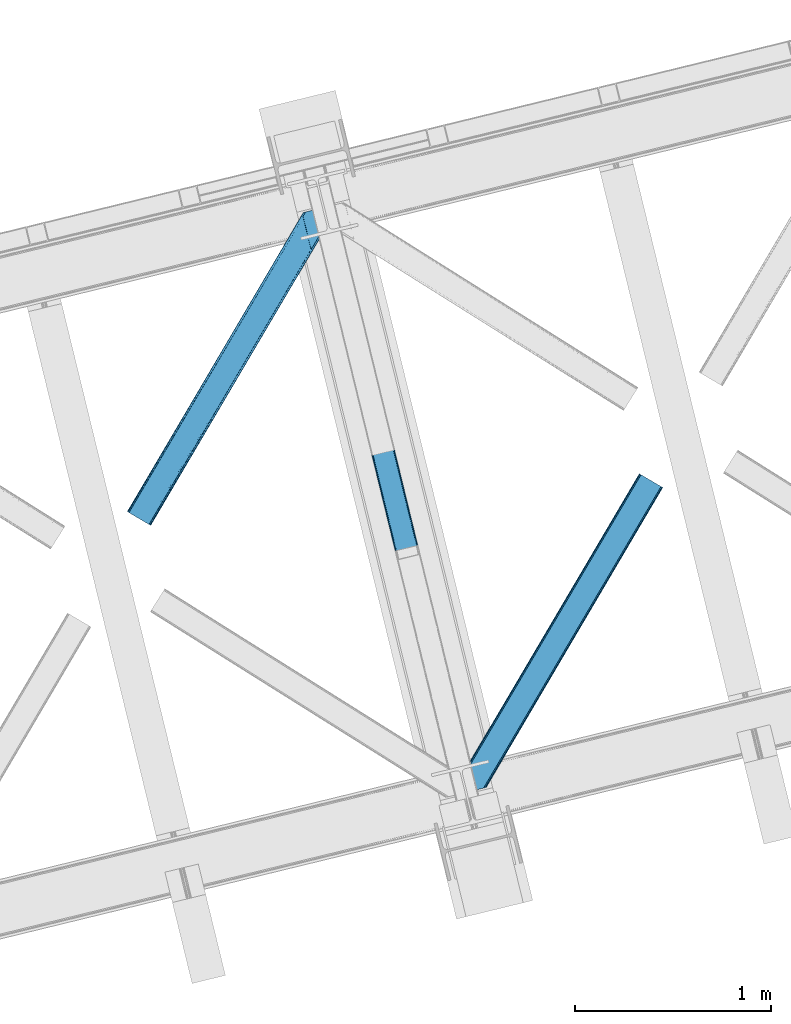
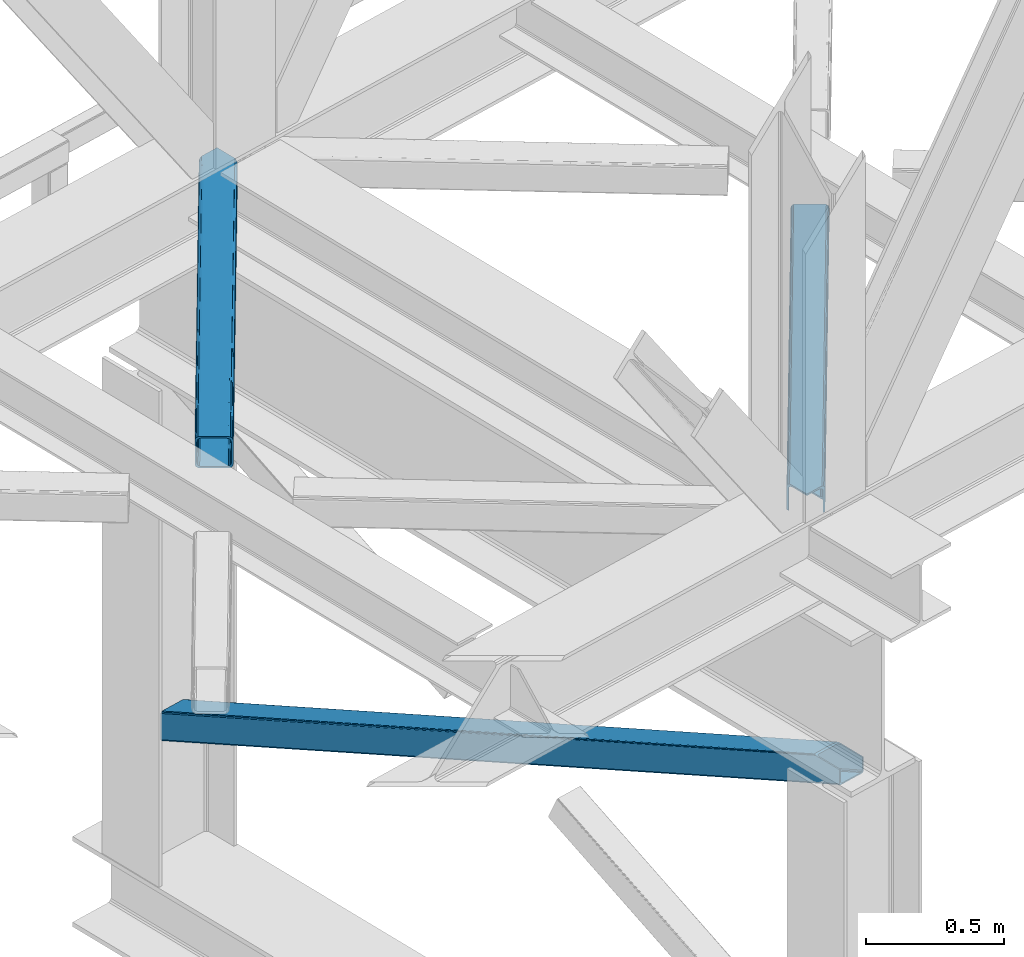
# One storey, part 29 of 93: 3 members.
"""IFC4 building model written with IfcOpenShell, lengths in millimetres."""

from ifc_helpers import new_model, entity, si_unit, converted_unit, derived_unit, direction, frame, origin, place, context, subcontext, project, spatial, triangles, type_object, element, save


model = new_model("IFC4")

# Units and contexts
model_context = context("Model", 3, precision=0.01, world=origin(), true_north=direction((6.12303176911189e-17, 1.0)))
plan_context = context("Plan", 3, precision=0.01, world=origin(), true_north=direction((6.12303176911189e-17, 1.0)))
body_context = subcontext(model_context, "Body", "Model", "MODEL_VIEW")
ifc_project = project(units=[si_unit("LENGTHUNIT", "METRE", prefix="MILLI"), si_unit("AREAUNIT", "SQUARE_METRE"), si_unit("VOLUMEUNIT", "CUBIC_METRE"), converted_unit("PLANEANGLEUNIT", "DEGREE", entity("IfcRatioMeasure", 0.0174532925199433), si_unit("PLANEANGLEUNIT", "RADIAN"), dimensions=[0, 0, 0, 0, 0, 0, 0]), si_unit("MASSUNIT", "GRAM", prefix="KILO"), derived_unit("MASSDENSITYUNIT", [(si_unit("MASSUNIT", "GRAM", prefix="KILO"), 1), (si_unit("LENGTHUNIT", "METRE"), -3)]), derived_unit("MOMENTOFINERTIAUNIT", [(si_unit("LENGTHUNIT", "METRE"), 4)]), si_unit("TIMEUNIT", "SECOND"), si_unit("FREQUENCYUNIT", "HERTZ"), si_unit("THERMODYNAMICTEMPERATUREUNIT", "DEGREE_CELSIUS"), derived_unit("THERMALTRANSMITTANCEUNIT", [(si_unit("MASSUNIT", "GRAM", prefix="KILO"), 1), (si_unit("THERMODYNAMICTEMPERATUREUNIT", "KELVIN"), -1), (si_unit("TIMEUNIT", "SECOND"), -3)]), derived_unit("VOLUMETRICFLOWRATEUNIT", [(si_unit("LENGTHUNIT", "METRE"), 3), (si_unit("TIMEUNIT", "SECOND"), -1)]), derived_unit("MASSFLOWRATEUNIT", [(si_unit("MASSUNIT", "GRAM", prefix="KILO"), 1), (si_unit("TIMEUNIT", "SECOND"), -1)]), derived_unit("ROTATIONALFREQUENCYUNIT", [(si_unit("TIMEUNIT", "SECOND"), -1)]), si_unit("ELECTRICCURRENTUNIT", "AMPERE"), si_unit("ELECTRICVOLTAGEUNIT", "VOLT"), si_unit("POWERUNIT", "WATT"), si_unit("FORCEUNIT", "NEWTON", prefix="KILO"), si_unit("ILLUMINANCEUNIT", "LUX"), si_unit("LUMINOUSFLUXUNIT", "LUMEN"), si_unit("LUMINOUSINTENSITYUNIT", "CANDELA"), derived_unit("USERDEFINED", [(si_unit("MASSUNIT", "GRAM", prefix="KILO"), -1), (si_unit("LENGTHUNIT", "METRE"), -2), (si_unit("TIMEUNIT", "SECOND"), 3), (si_unit("LUMINOUSFLUXUNIT", "LUMEN"), 1)]), derived_unit("LINEARVELOCITYUNIT", [(si_unit("LENGTHUNIT", "METRE"), 1), (si_unit("TIMEUNIT", "SECOND"), -1)]), si_unit("PRESSUREUNIT", "PASCAL"), derived_unit("USERDEFINED", [(si_unit("LENGTHUNIT", "METRE"), -2), (si_unit("MASSUNIT", "GRAM", prefix="KILO"), 1), (si_unit("TIMEUNIT", "SECOND"), -2)]), derived_unit("LINEARFORCEUNIT", [(si_unit("MASSUNIT", "GRAM", prefix="KILO"), 1), (si_unit("LENGTHUNIT", "METRE"), 1), (si_unit("TIMEUNIT", "SECOND"), -2), (si_unit("LENGTHUNIT", "METRE"), -1)]), derived_unit("PLANARFORCEUNIT", [(si_unit("MASSUNIT", "GRAM", prefix="KILO"), 1), (si_unit("LENGTHUNIT", "METRE"), 1), (si_unit("TIMEUNIT", "SECOND"), -2), (si_unit("LENGTHUNIT", "METRE"), -2)])], contexts=[model_context, plan_context])

# Site, building, storey
site_placement = place(None, origin())
site = spatial("IfcSite", under=ifc_project, at=site_placement, CompositionType="ELEMENT")
building_placement = place(site_placement, origin())
building = spatial("IfcBuilding", under=site, at=building_placement, CompositionType="ELEMENT")
storey_placement = place(building_placement, frame((0.0, 0.0, 15900.0)))
storey = spatial("IfcBuildingStorey", under=building, at=storey_placement, CompositionType="ELEMENT", Elevation=15900.0)

# Members
member_type_1 = type_object("IfcMemberType", PredefinedType="BRACE")
member_1_placement = place(storey_placement, frame((-55294.262109375, 4087.91210632324, 911.279672241211)))
element("IfcMember", 1, at=member_1_placement, inside=storey, type_object=member_type_1, ObjectType="Steel Vertical Brace", PredefinedType="BRACE", context=body_context, shape_type="Tessellation", body=[
    triangles([(109.783996582031, 3493.74488525391, 0.0), (954.899853515621, 26.7611572265623, 1610.78191223144), (6.79958496093604, 3468.64118499756, 0.0), (851.915441894525, 1.65774765014658, 1610.78191223144), (112.188500976561, 3494.33089599609, 1.12551269531104), (957.30435791015, 27.3474586486818, 1611.90626220703), (114.593005371091, 3494.91690673828, 2.24986267089844), (959.708862304688, 27.9334693908695, 1613.03061218261), (115.588293457025, 3495.15991516113, 4.96481323242188), (960.704150390622, 28.1761871337894, 1615.74672546387), (116.588232421869, 3495.40234222412, 7.68092651366896), (961.699438476557, 28.4189048767093, 1618.46167602539), (0.99528808593459, 3467.22615509033, 4.96481323242188), (846.111145019531, 0.242717742919922, 1615.74672546387), (0.0, 3466.98372802734, 7.68092651366896), (845.115856933589, 0.0, 1618.46167602539), (1.99057617186918, 3467.46916351318, 2.24986267089844), (847.106433105466, 0.485435485839844, 1613.03061218261), (4.39508056640625, 3468.05517425537, 1.12551269531104), (849.510937499996, 1.07144622802753, 1611.90626220703), (933.347680664061, 144.732444763184, 1680.7206665039), (116.588232421869, 3495.40234222412, 123.979641723632), (961.699438476557, 28.4189048767093, 1680.7206665039), (816.759448242185, 116.313539886474, 1680.7206665039), (0.0, 3466.98372802734, 123.979641723632), (845.115856933589, 0.0, 1680.7206665039), (112.188500976561, 3494.33089599609, 130.53505554199), (109.783996582031, 3493.74488525391, 131.659405517577), (922.5157836914, 159.605083465576, 1680.7206665039), (114.593005371091, 3494.91690673828, 129.409542846679), (925.427233886716, 158.980993652343, 1680.7206665039), (115.588293457025, 3495.15991516113, 126.694592285156), (928.506115722652, 155.935830688477, 1680.7206665039), (931.287341308591, 150.932357025146, 1680.7206665039), (6.79958496093604, 3468.64118499756, 131.659405517577), (819.531372070313, 134.501383209228, 1680.7206665039), (815.73625488281, 122.76547164917, 1680.7206665039), (0.99528808593459, 3467.22615509033, 126.694592285156), (815.903686523438, 128.487506103515, 1680.7206665039), (1.99057617186918, 3467.46916351318, 129.409542846679), (817.23848876953, 132.608766174317, 1680.7206665039), (4.39508056640625, 3468.05517425537, 130.53505554199), (923.44595947265, 145.989635467529, 1680.7206665039), (926.524841308594, 142.94418182373, 1680.7206665039), (920.539160156244, 146.61343460083, 1680.7206665039), (931.366406249996, 131.74108657837, 1680.7206665039), (956.843920898435, 27.2349655151365, 1680.7206665039), (929.306066894525, 137.9407081604, 1680.7206665039), (823.638098144525, 117.864317321777, 1680.7206665039), (824.972900390625, 121.985577392578, 1680.7206665039), (827.27043457031, 123.878194427491, 1680.7206665039), (824.498510742182, 105.690060424805, 1680.7206665039), (823.475317382807, 112.142282867431, 1680.7206665039), (849.971374511719, 1.18393936157236, 1680.7206665039), (111.728063964838, 3494.21869354248, 118.492767333984), (110.732775878903, 3493.97568511963, 121.208880615231), (109.737487792969, 3493.73267669678, 123.923831176755), (107.332983398432, 3493.14666595459, 125.048181152342), (104.928479003902, 3492.5606552124, 126.173693847653), (11.6597534179673, 3469.82541503906, 126.173693847653), (9.2552490234375, 3469.23940429688, 125.048181152342), (6.85074462890043, 3468.65339355469, 123.923831176755), (5.85545654296584, 3468.41038513184, 121.208880615231), (4.85551757812209, 3468.16737670898, 118.492767333984), (111.728063964838, 3494.21869354248, 13.166638183593), (956.843920898435, 27.2349655151365, 1623.94738769531), (4.85551757812209, 3468.16737670898, 13.166638183593), (849.971374511719, 1.18393936157236, 1623.94738769531), (109.737487792969, 3493.73267669678, 7.73557434081886), (107.332983398432, 3493.14666595459, 6.61122436523146), (110.732775878903, 3493.97568511963, 10.4505249023423), (104.928479003902, 3492.5606552124, 5.48571166992042), (6.85074462890043, 3468.65339355469, 7.73557434081886), (5.85545654296584, 3468.41038513184, 10.4505249023423), (9.2552490234375, 3469.23940429688, 6.61122436523146), (11.6597534179673, 3469.82541503906, 5.48571166992042), (950.039685058589, 25.5772178649904, 1616.26762390137), (952.444189453119, 26.1632286071781, 1617.39197387695), (954.848693847656, 26.7492393493649, 1618.51748657227), (856.770959472655, 2.8419776916503, 1616.26762390137), (854.366455078125, 2.25567626953125, 1617.39197387695), (851.961950683588, 1.66966552734357, 1618.51748657227), (955.8486328125, 26.9922477722166, 1621.23243713379), (850.966662597653, 1.42665710449228, 1621.23243713379)], [[1, 2, 3], [4, 3, 2], [5, 6, 2], [2, 1, 5], [7, 8, 6], [6, 5, 7], [9, 10, 8], [8, 7, 9], [11, 12, 10], [10, 9, 11], [13, 14, 15], [16, 15, 14], [17, 18, 13], [14, 13, 18], [19, 20, 17], [18, 17, 20], [3, 4, 19], [20, 19, 4], [11, 21, 12], [21, 11, 22], [23, 12, 21], [24, 15, 16], [24, 25, 15], [16, 26, 24], [27, 28, 29], [30, 27, 31], [32, 30, 33], [22, 32, 34], [34, 21, 22], [33, 34, 32], [31, 33, 30], [29, 31, 27], [29, 28, 35], [35, 36, 29], [25, 24, 37], [38, 37, 39], [40, 39, 41], [42, 41, 36], [36, 35, 42], [41, 42, 40], [39, 40, 38], [37, 38, 25], [43, 44, 34], [33, 43, 34], [29, 33, 31], [45, 29, 36], [33, 45, 43], [29, 45, 33], [44, 21, 34], [23, 46, 47], [23, 21, 46], [44, 48, 21], [48, 46, 21], [37, 49, 50], [36, 51, 45], [51, 39, 50], [39, 51, 36], [50, 39, 37], [39, 36, 41], [24, 49, 37], [52, 53, 24], [53, 49, 24], [52, 26, 54], [24, 26, 52], [55, 46, 48], [56, 48, 44], [57, 44, 43], [58, 43, 45], [45, 59, 58], [43, 58, 57], [44, 57, 56], [48, 56, 55], [59, 45, 51], [51, 60, 59], [61, 60, 51], [62, 61, 50], [63, 62, 49], [64, 63, 53], [53, 52, 64], [49, 53, 63], [50, 49, 62], [51, 50, 61], [46, 65, 66], [46, 55, 65], [66, 47, 46], [67, 52, 68], [52, 67, 64], [54, 68, 52], [58, 59, 28], [32, 57, 27], [32, 27, 30], [28, 59, 35], [28, 27, 58], [57, 58, 27], [55, 22, 11], [22, 56, 57], [55, 56, 22], [22, 57, 32], [42, 62, 38], [60, 35, 59], [61, 42, 35], [61, 35, 60], [38, 40, 42], [62, 25, 38], [42, 61, 62], [62, 63, 25], [25, 64, 15], [64, 25, 63], [69, 5, 70], [11, 65, 55], [71, 11, 69], [11, 71, 65], [69, 11, 9], [70, 1, 72], [69, 9, 5], [5, 9, 7], [72, 1, 3], [5, 1, 70], [73, 13, 15], [74, 73, 15], [75, 19, 73], [67, 15, 64], [15, 67, 74], [19, 13, 73], [3, 76, 72], [19, 75, 3], [76, 3, 75], [17, 13, 19], [77, 4, 2], [2, 6, 78], [6, 8, 10], [6, 79, 78], [2, 78, 77], [79, 6, 10], [80, 4, 77], [18, 20, 14], [20, 4, 81], [81, 82, 20], [20, 82, 14], [80, 81, 4], [14, 82, 16], [83, 12, 66], [10, 12, 79], [83, 79, 12], [23, 66, 12], [23, 47, 66], [16, 84, 68], [84, 16, 82], [68, 26, 16], [26, 68, 54], [77, 72, 76], [76, 80, 77], [66, 65, 83], [71, 83, 65], [83, 71, 79], [69, 79, 71], [79, 69, 78], [70, 78, 69], [78, 70, 77], [72, 77, 70], [80, 76, 75], [75, 81, 80], [81, 75, 73], [73, 82, 81], [82, 73, 74], [74, 84, 82], [84, 74, 67], [67, 68, 84]]),
])
member_type_2 = type_object("IfcMemberType", PredefinedType="BRACE")
member_2_placement = place(storey_placement, frame((-56177.5849365234, 5705.46744232178, 3511.0000579834)))
element("IfcMember", 2, at=member_2_placement, inside=storey, type_object=member_type_2, ObjectType="Steel Horizontal Brace", PredefinedType="BRACE", context=body_context, shape_type="Tessellation", body=[
    triangles([(105.560998535155, 8.87794647216833, 0.0), (15.078149414061, 62.148532104492, 0.0), (892.843176269533, 1346.13992614746, 0.0), (857.166284179686, 1492.50250396729, 0.0), (854.892004394533, 1501.83739929199, 1.33247680664135), (9.30640869140916, 65.5459991455082, 1.33247680664135), (852.961889648439, 1509.75145111084, 5.12526855468968), (4.41368408202834, 68.4266372680668, 5.12526855468968), (851.673596191409, 1515.03950042725, 10.8028289794929), (1.14411621094041, 70.3509384155277, 10.8028289794929), (851.222460937497, 1516.89636383057, 17.5000946044929), (0.0, 71.0270599365231, 17.5000946044929), (893.633825683595, 1342.89768218994, 0.155804443362285), (111.332739257814, 5.48047943115216, 1.33247680664135), (899.559045410155, 1344.34178009033, 1.33247680664135), (912.390820312503, 1347.46949615478, 10.8028289794929), (914.195361328122, 1347.90958557129, 17.5000946044929), (120.643798828125, 0.0, 17.5000946044929), (119.495031738283, 0.675540161132631, 10.8028289794929), (907.251599121097, 1346.21666564941, 5.12526855468968), (116.225463867188, 2.60042266845721, 5.12526855468968), (902.493750000001, 1345.05743408203, 17.9802978515654), (893.633825683595, 1342.89768218994, 9.69243164062573), (897.763806152347, 1343.90459747314, 12.1260040283232), (903.721582031249, 1345.35683441162, 19.4999725341804), (914.195361328122, 1347.90958557129, 19.4999725341804), (1011.61732177735, 1513.38669433594, 19.4999725341804), (1008.98957519532, 1524.16103668213, 19.4999725341804), (1011.61732177735, 1513.38669433594, 122.500662231447), (120.643798828125, 0.0, 122.500662231447), (114.61160888672, 3.55094604492206, 24.4996673583992), (1009.23607177734, 1523.14423828125, 24.4996673583992), (113.462841796878, 4.22706756591833, 17.8035644531265), (110.193273925783, 6.15136871337927, 12.1260040283232), (105.300549316409, 9.03200683593786, 8.3320495605476), (99.52880859375, 12.4294738769531, 6.99957275390625), (892.685046386716, 1346.79976959229, 8.88434143066479), (890.466577148436, 1355.89747009277, 6.99957275390625), (21.1103393554658, 58.5970046997072, 6.99957275390625), (859.547534179685, 1482.74496002197, 6.99957275390625), (853.961828613283, 1505.66042175293, 18.5000335693367), (851.222460937497, 1516.89636383057, 18.5000335693367), (854.092053222659, 1505.10871124268, 17.8803039550803), (855.338488769528, 1499.99390716553, 12.1260040283232), (857.268603515622, 1492.07985534668, 8.3320495605476), (1009.23607177734, 1523.14423828125, 115.501089477541), (114.61160888672, 3.55094604492206, 115.501089477541), (1008.78493652344, 1525.00110168457, 122.196029663086), (113.462841796878, 4.22706756591833, 122.196029663086), (1007.49664306641, 1530.28856964111, 127.87475280762), (110.193273925783, 6.15136871337927, 127.87475280762), (1005.56652832031, 1538.20262145996, 131.667544555665), (105.300549316409, 9.03200683593786, 131.667544555665), (1003.29224853516, 1547.53809814453, 133.000021362306), (99.52880859375, 12.4294738769531, 133.000021362306), (851.947998046875, 1518.13291625977, 19.4999725341804), (854.575744628906, 1507.35857391357, 19.4999725341804), (851.775915527345, 1517.83991088867, 19.2639404296897), (854.426916503908, 1506.95045928955, 19.2592895507842), (851.585229492186, 1517.51434936523, 19.0000030517585), (854.268786621091, 1506.50920715332, 19.0000030517585), (851.394543457034, 1517.1887878418, 18.736065673831), (854.106005859372, 1506.06795501709, 18.7407165527366), (908.014343261719, 1598.12628936768, 19.4999725341804), (897.540563964845, 1595.57353820801, 19.4999725341804), (1011.16153564453, 1515.24355773926, 129.197927856447), (1009.8732421875, 1520.53160705566, 134.874325561526), (1008.43146972657, 1526.45624542236, 137.999716186525), (986.307238769528, 1617.21117095947, 137.999716186525), (986.307238769528, 1617.21117095947, 133.000021362306), (897.540563964845, 1595.57353820801, 122.500662231447), (0.0, 71.0270599365231, 122.500662231447), (7.17630615234521, 66.799411010742, 17.8035644531265), (10.4458740234404, 64.8751098632811, 12.1260040283232), (6.03218994140479, 67.4755325317383, 24.4996673583992), (907.023706054686, 1597.88560638428, 24.4996673583992), (15.338598632814, 61.9944717407225, 8.3320495605476), (908.828247070313, 1598.32511444092, 122.196029663086), (899.345104980472, 1596.01362762451, 129.197927856447), (904.484326171878, 1597.26645812988, 134.874325561526), (930.73388671875, 1603.66490478516, 133.000021362306), (910.24211425781, 1598.66986083984, 137.999716186525), (921.660021972653, 1601.45341186523, 131.667544555665), (913.967468261719, 1599.57852630615, 127.87475280762), (907.023706054686, 1597.88560638428, 115.501089477541), (21.1103393554658, 58.5970046997072, 133.000021362306), (6.03218994140479, 67.4755325317383, 115.501089477541), (15.338598632814, 61.9944717407225, 131.667544555665), (10.4458740234404, 64.8751098632811, 127.87475280762), (7.17630615234521, 66.799411010742, 122.196029663086), (119.495031738283, 0.675540161132631, 129.197927856447), (116.225463867188, 2.60042266845721, 134.874325561526), (111.332739257814, 5.48047943115216, 138.667117309571), (105.560998535155, 8.87794647216833, 139.999594116212), (15.078149414061, 62.148532104492, 139.999594116212), (9.30640869140916, 65.5459991455082, 138.667117309571), (4.41368408202834, 68.4266372680668, 134.874325561526), (1.14411621094041, 70.3509384155277, 129.197927856447), (896.987109374997, 1576.15553741455, 137.999716186525), (938.18924560547, 1407.14434204102, 137.999716186525), (899.019543457034, 1563.59525756836, 139.999594116212), (897.038269042969, 1571.72266845703, 138.999655151369), (896.796423339845, 1573.13653564453, 138.639212036134), (896.926647949222, 1575.15443572998, 138.211331176761), (896.86153564453, 1574.14112548828, 138.427597045898), (937.473010253903, 1407.08562469482, 138.29272155762), (937.077685546872, 1408.09486541748, 138.646188354494), (936.682360839841, 1409.10410614014, 138.999655151369), (934.701086425783, 1417.23267974853, 139.999594116212)], [[1, 2, 3], [4, 3, 2], [5, 4, 6], [2, 6, 4], [7, 5, 8], [6, 8, 5], [9, 7, 10], [8, 10, 7], [11, 9, 12], [10, 12, 9], [1, 3, 13], [13, 14, 1], [13, 15, 14], [16, 17, 18], [18, 19, 16], [20, 16, 19], [19, 21, 20], [15, 20, 21], [21, 14, 15], [20, 22, 16], [23, 24, 15], [23, 15, 13], [15, 24, 20], [16, 25, 17], [20, 24, 22], [16, 22, 25], [26, 17, 25], [26, 25, 27], [28, 27, 25], [27, 29, 26], [30, 26, 29], [26, 18, 17], [30, 18, 26], [31, 32, 25], [25, 33, 31], [25, 22, 33], [32, 28, 25], [33, 22, 24], [34, 24, 23], [23, 35, 34], [36, 35, 37], [37, 38, 36], [23, 37, 35], [24, 34, 33], [39, 36, 38], [38, 40, 39], [9, 11, 41], [11, 42, 41], [43, 9, 41], [43, 7, 9], [44, 7, 43], [5, 44, 45], [44, 5, 7], [4, 5, 45], [45, 40, 4], [37, 23, 13], [37, 3, 38], [3, 40, 38], [40, 3, 4], [37, 13, 3], [46, 32, 31], [31, 47, 46], [48, 46, 49], [47, 49, 46], [50, 48, 51], [49, 51, 48], [52, 50, 53], [51, 53, 50], [54, 52, 55], [53, 55, 52], [56, 57, 58], [59, 58, 57], [58, 59, 60], [61, 60, 59], [60, 61, 62], [63, 62, 61], [62, 63, 42], [41, 42, 63], [57, 56, 64], [65, 64, 56], [66, 48, 67], [46, 29, 27], [27, 32, 46], [32, 27, 28], [48, 29, 46], [66, 29, 48], [50, 68, 67], [52, 68, 50], [67, 48, 50], [52, 54, 68], [54, 69, 68], [70, 69, 54], [71, 60, 62], [58, 60, 71], [71, 56, 58], [56, 71, 65], [42, 12, 72], [12, 42, 11], [71, 42, 72], [42, 71, 62], [73, 74, 44], [75, 73, 43], [43, 41, 75], [43, 57, 75], [64, 76, 57], [75, 57, 76], [44, 43, 73], [45, 44, 74], [74, 77, 45], [40, 45, 77], [77, 39, 40], [78, 79, 80], [81, 82, 69], [69, 70, 81], [81, 83, 82], [84, 82, 83], [80, 82, 84], [78, 71, 79], [85, 71, 78], [80, 84, 78], [65, 76, 64], [85, 65, 71], [76, 65, 85], [86, 54, 55], [54, 86, 81], [70, 54, 81], [76, 85, 87], [87, 75, 76], [83, 81, 86], [86, 88, 83], [84, 83, 88], [88, 89, 84], [78, 84, 89], [89, 90, 78], [85, 78, 90], [90, 87, 85], [91, 51, 49], [47, 18, 30], [91, 49, 30], [91, 92, 51], [49, 47, 30], [51, 92, 93], [55, 94, 95], [94, 53, 93], [53, 94, 55], [53, 51, 93], [19, 34, 21], [31, 18, 47], [18, 33, 19], [33, 18, 31], [19, 33, 34], [1, 36, 2], [14, 21, 34], [34, 35, 14], [35, 36, 1], [1, 14, 35], [89, 96, 97], [95, 86, 55], [95, 88, 86], [88, 95, 96], [89, 88, 96], [87, 72, 12], [98, 90, 89], [97, 98, 89], [90, 98, 72], [87, 90, 72], [6, 74, 8], [2, 36, 39], [39, 77, 2], [77, 74, 6], [6, 2, 77], [10, 8, 74], [12, 75, 87], [73, 12, 10], [12, 73, 75], [73, 10, 74], [99, 68, 82], [99, 100, 68], [68, 69, 82], [96, 95, 101], [101, 102, 96], [97, 96, 103], [104, 97, 105], [104, 99, 97], [97, 103, 105], [82, 80, 99], [97, 99, 80], [102, 103, 96], [79, 71, 98], [72, 98, 71], [80, 79, 97], [98, 97, 79], [92, 67, 100], [100, 93, 92], [67, 68, 100], [106, 107, 93], [94, 93, 107], [107, 108, 94], [108, 109, 94], [66, 67, 92], [92, 91, 66], [29, 66, 91], [91, 30, 29], [95, 94, 109], [109, 101, 95], [107, 103, 102], [105, 103, 107], [106, 104, 105], [100, 99, 104], [107, 106, 105], [102, 108, 107], [102, 101, 109], [109, 108, 102]]),
])
member_type_3 = type_object("IfcMemberType", PredefinedType="BRACE")
member_3_placement = place(storey_placement, frame((-54460.7408935547, 4348.57584686279, 3511.0000579834)))
element("IfcMember", 3, at=member_3_placement, inside=storey, type_object=member_type_3, ObjectType="Steel Horizontal Brace", PredefinedType="BRACE", context=body_context, shape_type="Tessellation", body=[
    triangles([(154.451037597661, 124.708957672119, 0.0), (118.774145507814, 271.071535491944, 0.0), (998.971582031256, 1559.19901428223, 0.0), (908.488732910162, 1612.46901855469, 0.0), (1004.74332275391, 1555.80096588135, 1.33247680664135), (156.725317382814, 115.37377166748, 1.33247680664135), (1009.63604736328, 1552.92090911865, 5.12526855468968), (158.655432128908, 107.459719848634, 5.12526855468968), (1012.90561523438, 1550.99602661133, 10.8028289794929), (159.943725585938, 102.171961212159, 10.8028289794929), (1014.05438232422, 1550.3204864502, 17.5000946044929), (160.39486083985, 100.315097808838, 17.5000946044929), (902.716992187503, 1615.8664855957, 1.33247680664135), (116.495214843751, 280.406721496583, 1.33247680664135), (114.579052734378, 288.275717926026, 5.17061462402489), (897.824267578129, 1618.74712371826, 5.12526855468968), (114.499987792973, 288.596628570557, 5.32641906738354), (894.554699707034, 1620.67142486572, 10.8028289794929), (109.630517578131, 287.409491729737, 10.8028289794929), (893.410583496094, 1621.34754638672, 17.5000946044929), (107.825976562504, 286.969402313232, 17.5000946044929), (113.527954101563, 288.360015106202, 18.5197998046897), (114.499987792973, 288.596628570557, 17.5198608398459), (114.42557373047, 288.578606414795, 17.9023956298843), (114.216284179689, 288.527446746826, 18.2279571533218), (113.900024414063, 288.450416564941, 18.4442230224631), (107.825976562504, 286.969402313232, 18.5197998046897), (115.695263671878, 283.683847045899, 17.5198608398459), (115.625500488284, 283.800700378419, 17.8035644531265), (115.569689941411, 283.740529632569, 17.8570495605491), (115.323193359378, 283.495777130127, 18.0768035888686), (115.067395019534, 283.23939743042, 18.3081848144539), (114.834851074222, 283.003365325928, 18.5197998046897), (0.0, 103.824767303468, 18.5197998046897), (2.73936767578562, 92.5989990234375, 18.5197998046897), (893.410583496094, 1621.34754638672, 122.500662231447), (0.0, 103.824767303468, 122.500662231447), (908.488732910162, 1612.46901855469, 139.999594116212), (902.716992187503, 1615.8664855957, 138.667117309571), (3.6741943359375, 88.7660934448249, 138.667117309571), (5.94847412109812, 79.4309074401863, 139.999594116212), (897.824267578129, 1618.74712371826, 134.874325561526), (1.74407958984375, 96.6801452636719, 134.874325561526), (894.554699707034, 1620.67142486572, 129.197927856447), (0.455786132813955, 101.967903900147, 129.197927856447), (899.442773437506, 1617.79601898193, 24.4996673583992), (2.38125000000582, 94.0672233581545, 24.4996673583992), (900.591540527348, 1617.1204788208, 17.8035644531265), (903.856457519534, 1615.19559631348, 12.1260040283232), (914.520922851567, 1608.9174911499, 6.99957275390625), (908.749182128908, 1612.31553955078, 8.3320495605476), (118.87646484375, 270.64917755127, 8.3320495605476), (121.150744628911, 261.313991546631, 6.99957275390625), (116.946350097656, 278.563229370117, 12.1260040283232), (152.069787597662, 134.466501617432, 6.99957275390625), (992.939392089844, 1562.74996032715, 6.99957275390625), (156.274182128909, 117.217263793946, 12.1260040283232), (154.344067382815, 125.131315612794, 8.3320495605476), (157.525268554688, 112.096936798096, 17.5198608398459), (160.39486083985, 100.315097808838, 17.5198608398459), (899.442773437506, 1617.79601898193, 115.501089477541), (2.38125000000582, 94.0672233581545, 115.501089477541), (900.591540527348, 1617.1204788208, 122.196029663086), (2.83238525391062, 92.2103599548345, 122.196029663086), (903.856457519534, 1615.19559631348, 127.87475280762), (4.12067871094041, 86.9226013183597, 127.87475280762), (908.749182128908, 1612.31553955078, 131.667544555665), (6.05079345703416, 79.0085494995119, 131.667544555665), (914.520922851567, 1608.9174911499, 133.000021362306), (8.3250732421875, 69.6736541748051, 133.000021362306), (25.3100830078183, 0.0, 133.000021362306), (25.3100830078183, 0.0, 139.999594116212), (90.3665771484375, 15.8583343505861, 139.999594116212), (998.971582031256, 1559.19901428223, 139.999594116212), (1014.05438232422, 1550.3204864502, 122.500662231447), (1012.90561523438, 1550.99602661133, 129.197927856447), (114.076757812501, 21.6379234313972, 122.500662231447), (112.272216796875, 21.1978340148926, 129.197927856447), (1009.63604736328, 1552.92090911865, 134.874325561526), (107.132995605469, 19.9450035095215, 134.874325561526), (1004.74332275391, 1555.80096588135, 138.667117309571), (99.4404418945342, 18.0698272705085, 138.667117309571), (159.669323730472, 99.0785453796389, 18.5197998046897), (114.076757812501, 21.6379234313972, 18.5197998046897), (103.165795898443, 18.9782020568855, 18.5197998046897), (156.929956054693, 110.3046043396, 18.5197998046897), (1008.02219238281, 1553.87201385498, 24.4996673583992), (1006.87342529297, 1554.54755401611, 17.8035644531265), (157.22761230469, 111.200770568848, 18.0198303222678), (1003.60385742188, 1556.47243652344, 12.1260040283232), (998.711132812503, 1559.35249328613, 8.3320495605476), (104.593615722661, 19.3261459350588, 24.4996673583992), (1003.60385742188, 1556.47243652344, 127.87475280762), (1008.02219238281, 1553.87201385498, 115.501089477541), (1006.87342529297, 1554.54755401611, 122.196029663086), (992.939392089844, 1562.74996032715, 133.000021362306), (998.711132812503, 1559.35249328613, 131.667544555665), (102.789074707034, 18.8860565185551, 122.196029663086), (80.8834350585967, 13.5465568542486, 133.000021362306), (89.9572998046933, 15.7580497741701, 131.667544555665), (97.6498535156279, 17.633226013184, 127.87475280762), (104.593615722661, 19.3261459350588, 115.501089477541)], [[1, 2, 3], [4, 3, 2], [3, 5, 1], [6, 1, 5], [5, 7, 6], [8, 6, 7], [7, 9, 8], [10, 8, 9], [9, 11, 10], [12, 10, 11], [13, 14, 15], [16, 15, 17], [17, 18, 16], [17, 19, 18], [20, 18, 19], [19, 21, 20], [15, 16, 13], [13, 4, 14], [2, 14, 4], [22, 23, 24], [22, 25, 26], [27, 21, 22], [24, 25, 22], [23, 22, 21], [21, 19, 23], [17, 23, 19], [23, 28, 29], [29, 24, 23], [25, 24, 30], [26, 25, 31], [22, 26, 32], [32, 33, 22], [31, 32, 26], [30, 31, 25], [29, 30, 24], [34, 33, 35], [33, 34, 27], [22, 33, 27], [27, 20, 21], [36, 27, 37], [27, 36, 20], [27, 34, 37], [38, 39, 40], [40, 41, 38], [39, 42, 43], [43, 40, 39], [42, 44, 45], [45, 43, 42], [44, 36, 37], [37, 45, 44], [46, 47, 33], [33, 48, 46], [33, 31, 48], [47, 35, 33], [49, 48, 28], [50, 51, 52], [52, 53, 50], [51, 49, 54], [54, 52, 51], [28, 54, 49], [53, 55, 56], [56, 50, 53], [55, 2, 1], [54, 17, 14], [52, 14, 2], [52, 2, 53], [55, 53, 2], [17, 28, 23], [54, 28, 17], [52, 54, 14], [57, 58, 6], [58, 1, 6], [1, 58, 55], [8, 57, 6], [8, 59, 57], [10, 59, 8], [10, 60, 59], [46, 61, 47], [62, 47, 61], [61, 63, 62], [64, 62, 63], [63, 65, 64], [66, 64, 65], [65, 67, 66], [68, 66, 67], [67, 69, 68], [70, 68, 69], [66, 43, 64], [71, 72, 70], [72, 41, 70], [40, 68, 41], [66, 68, 40], [68, 70, 41], [66, 40, 43], [37, 34, 62], [45, 64, 43], [62, 64, 37], [64, 45, 37], [34, 47, 62], [34, 35, 47], [41, 73, 74], [73, 41, 72], [74, 38, 41], [75, 76, 77], [78, 77, 76], [76, 79, 78], [80, 78, 79], [79, 81, 80], [82, 80, 81], [81, 74, 82], [73, 82, 74], [60, 75, 77], [60, 11, 75], [77, 83, 60], [77, 84, 83], [84, 85, 83], [86, 83, 85], [87, 88, 59], [89, 86, 87], [88, 90, 57], [57, 59, 88], [90, 91, 58], [58, 57, 90], [91, 56, 55], [55, 58, 91], [87, 86, 92], [85, 92, 86], [9, 90, 88], [87, 75, 11], [9, 88, 11], [9, 7, 90], [88, 87, 11], [90, 7, 5], [56, 3, 4], [3, 91, 5], [91, 3, 56], [91, 90, 5], [76, 93, 79], [94, 75, 87], [75, 95, 76], [95, 75, 94], [76, 95, 93], [74, 96, 38], [81, 79, 93], [93, 97, 81], [97, 96, 74], [74, 81, 97], [49, 13, 16], [4, 50, 56], [4, 51, 50], [51, 4, 13], [49, 51, 13], [46, 20, 36], [18, 48, 49], [16, 18, 49], [48, 18, 20], [46, 48, 20], [39, 65, 42], [38, 96, 69], [69, 67, 38], [67, 65, 39], [39, 38, 67], [44, 42, 65], [36, 61, 46], [63, 36, 44], [36, 63, 61], [63, 44, 65], [98, 78, 80], [99, 73, 72], [72, 71, 99], [99, 100, 73], [100, 82, 73], [101, 82, 100], [80, 82, 101], [98, 77, 78], [102, 77, 98], [80, 101, 98], [84, 92, 85], [102, 84, 77], [92, 84, 102], [99, 70, 96], [99, 71, 70], [69, 96, 70], [96, 97, 100], [100, 99, 96], [97, 93, 101], [101, 100, 97], [93, 95, 98], [98, 101, 93], [95, 94, 102], [102, 98, 95], [94, 87, 102], [92, 102, 87]]),
])

save(model, "model.ifc")
